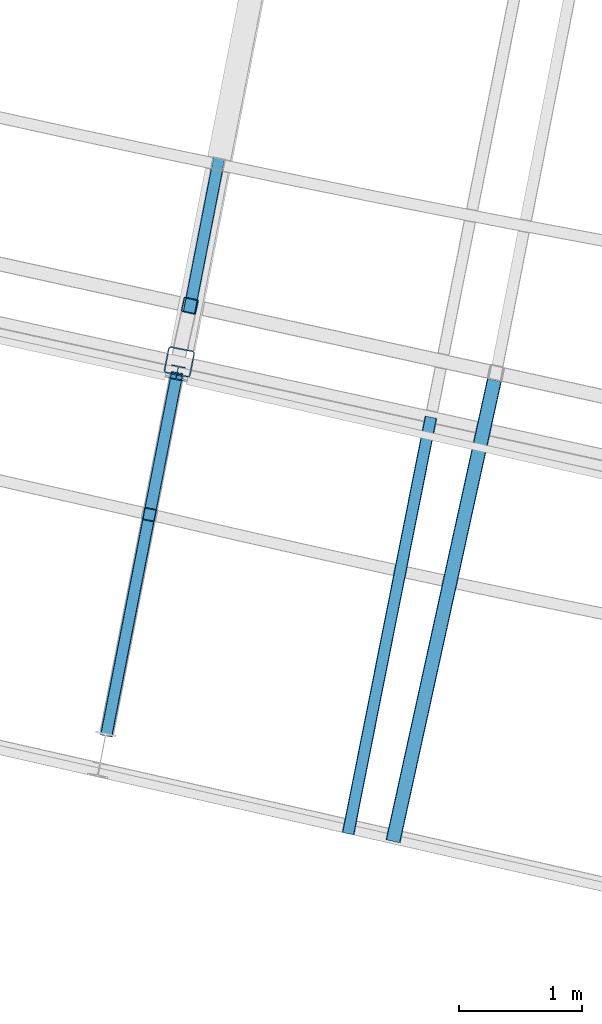
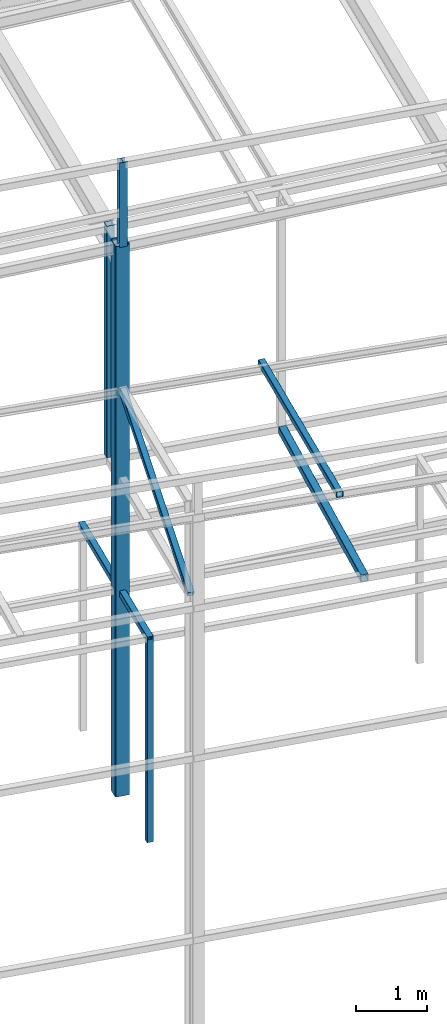
# One storey, part 28 of 215: 8 beams, 1 member, 9 elements without a shape of their own.
"""IFC2X3 building model written with IfcOpenShell, lengths in millimetres."""

from ifc_helpers import new_model, si_unit, frame, origin_with_axes, origin_2d_with_axis, place, context, subcontext, project, spatial, hollow_rectangle, i_section, extrude, clip, halfspace, material, type_object, element, aggregate, save


model = new_model("IFC2X3")

# Units and contexts
model_context = context("Model", 3, precision=1e-05, world=origin_with_axes())
body_context = subcontext(model_context, "Body", "Model", "MODEL_VIEW")
ifc_project = project(units=[si_unit("LENGTHUNIT", "METRE", prefix="MILLI"), si_unit("AREAUNIT", "SQUARE_METRE"), si_unit("VOLUMEUNIT", "CUBIC_METRE"), si_unit("MASSUNIT", "GRAM", prefix="KILO"), si_unit("TIMEUNIT", "SECOND"), si_unit("PLANEANGLEUNIT", "RADIAN"), si_unit("SOLIDANGLEUNIT", "STERADIAN"), si_unit("THERMODYNAMICTEMPERATUREUNIT", "DEGREE_CELSIUS"), si_unit("LUMINOUSINTENSITYUNIT", "LUMEN")], contexts=[model_context])

# Site, building, storey
site_placement = place(None, origin_with_axes())
site = spatial("IfcSite", under=ifc_project, at=site_placement, CompositionType="ELEMENT")
building_placement = place(site_placement, origin_with_axes())
building = spatial("IfcBuilding", under=site, at=building_placement, Name="Undefined", CompositionType="ELEMENT")
storey_placement = place(building_placement, origin_with_axes())
storey = spatial("IfcBuildingStorey", under=building, at=storey_placement, Name="Undefined", CompositionType="ELEMENT", Elevation=0.0)

# Assembly, beam
assembly_1_placement = place(storey_placement, origin_with_axes())
assembly_1 = element("IfcElementAssembly", 1, at=assembly_1_placement, inside=storey, Name="Steel Assembly", AssemblyPlace="NOTDEFINED", PredefinedType="RIGID_FRAME")
ifc_material = material(Name="STEEL/S275JR")
beam_type_1 = type_object("IfcBeamType", PredefinedType="NOTDEFINED")
beam_1_placement = place(assembly_1_placement, frame((59714.7878050659, 5675.63674681573, 6760.00000147429), z_axis=(-0.981422412140383, 0.191859451027444, 0.0), x_axis=(0.0, 0.0, -1.0)))
beam_1 = element("IfcBeam", 2, at=beam_1_placement, type_object=beam_type_1, material=ifc_material, Name="MONTANT", context=body_context, shape_type="SweptSolid", body=[
    extrude(hollow_rectangle(XDim=100.0, YDim=100.0, WallThickness=4.0, InnerFilletRadius=4.0, OuterFilletRadius=8.0, at=origin_2d_with_axis()), frame((3499.99999998675, 0.0, 0.0), z_axis=(-1.0, 0.0, 0.0), x_axis=(-6.93889390390723e-18, -1.0, -3.46944695195361e-18)), (0.0, 0.0, 1.0), 3500.0),
])
aggregate(assembly_1, [beam_1])

assembly_2_placement = place(storey_placement, origin_with_axes())
assembly_2 = element("IfcElementAssembly", 3, at=assembly_2_placement, inside=storey, Name="Steel Assembly", AssemblyPlace="NOTDEFINED", PredefinedType="RIGID_FRAME")
beam_2_placement = place(assembly_2_placement, frame((59705.2313155616, 5626.55621663532, 6760.00000147687), z_axis=(-0.981443928514775, 0.191749355100574, 0.0), x_axis=(0.191749355100576, 0.981443928514774, 0.0)))
beam_2 = element("IfcBeam", 4, at=beam_2_placement, type_object=beam_type_1, material=ifc_material, Name="POUTRE", context=body_context, shape_type="Clipping", body=[
    clip(extrude(hollow_rectangle(XDim=100.0, YDim=100.0, WallThickness=4.0, InnerFilletRadius=4.0, OuterFilletRadius=8.0, at=origin_2d_with_axis()), frame((1205.10261709792, 9.09494701772928e-13, 0.0), z_axis=(-1.0, 0.0, 0.0), x_axis=(-6.93889390390723e-18, -1.0, -3.46944695195361e-18)), (0.0, 0.0, 1.0), 1205.1), halfspace(frame((1205.11495562573, -49.9999999999991, 109.989902511399), z_axis=(-0.999999993707966, 0.0, 0.000112178729892983), x_axis=(-6.93889390390723e-18, -1.0, -3.46944695195361e-18)), True)),
])
aggregate(assembly_2, [beam_2])

assembly_3_placement = place(storey_placement, origin_with_axes())
assembly_3 = element("IfcElementAssembly", 5, at=assembly_3_placement, inside=storey, Name="Steel Assembly", AssemblyPlace="NOTDEFINED", PredefinedType="RIGID_FRAME")
beam_3_placement = place(assembly_3_placement, frame((59995.7953493763, 7113.53585944618, 6760.00000147687), z_axis=(-0.981422412140383, 0.191859451027444, 0.0), x_axis=(0.191859470081235, 0.981422408415534, 0.0)))
beam_3 = element("IfcBeam", 6, at=beam_3_placement, type_object=beam_type_1, material=ifc_material, Name="POUTRE", context=body_context, shape_type="Clipping", body=[
    clip(extrude(hollow_rectangle(XDim=100.0, YDim=100.0, WallThickness=4.0, InnerFilletRadius=4.0, OuterFilletRadius=8.0, at=origin_2d_with_axis()), frame((1486.70401782648, 0.0, 4.12643257848422e-14), z_axis=(-1.0, 0.0, 0.0), x_axis=(-6.93889390390723e-18, -1.0, -3.46944695195361e-18)), (0.0, 0.0, 1.0), 1576.7), halfspace(frame((-89.9999938967303, -50.0, -109.99995330286), z_axis=(1.0, 0.0, 0.0), x_axis=(-6.93889390390723e-18, -1.0, -3.46944695195361e-18)), True)),
])
aggregate(assembly_3, [beam_3])

assembly_4_placement = place(storey_placement, origin_with_axes())
assembly_4 = element("IfcElementAssembly", 7, at=assembly_4_placement, inside=storey, Name="Steel Assembly", AssemblyPlace="NOTDEFINED", PredefinedType="RIGID_FRAME")
beam_type_2 = type_object("IfcBeamType", PredefinedType="NOTDEFINED")
beam_4_placement = place(assembly_4_placement, frame((62518.9973398517, 6768.47178494175, 8706.00017320451), z_axis=(0.976696868550088, -0.214623453901133, -1.0000003380751e-09), x_axis=(-0.214623453901134, -0.976696868550088, 0.0)))
beam_4 = element("IfcBeam", 8, at=beam_4_placement, type_object=beam_type_2, material=ifc_material, Name="LISSE", context=body_context, shape_type="SweptSolid", body=[
    extrude(hollow_rectangle(XDim=120.0, YDim=120.0, WallThickness=5.0, InnerFilletRadius=5.0, OuterFilletRadius=10.0, at=origin_2d_with_axis()), frame((3838.62759718365, 1.81898940364508e-12, 1.06543318533871e-13), z_axis=(-1.0, 0.0, 0.0), x_axis=(-6.93889390390723e-18, -1.0, -3.46944695195361e-18)), (0.0, 0.0, 1.0), 3838.6),
])
aggregate(assembly_4, [beam_4])

assembly_5_placement = place(storey_placement, origin_with_axes())
assembly_5 = element("IfcElementAssembly", 9, at=assembly_5_placement, inside=storey, Name="Steel Assembly", AssemblyPlace="NOTDEFINED", PredefinedType="RIGID_FRAME")
beam_5_placement = place(assembly_5_placement, frame((60043.166993633, 7373.72721898546, 12762.4504231558), z_axis=(-0.214538758981639, -0.97671547591641, 0.0), x_axis=(0.0, 0.0, -1.0)))
beam_5 = element("IfcBeam", 10, at=beam_5_placement, type_object=beam_type_2, material=ifc_material, Name="LISSE", context=body_context, shape_type="SweptSolid", body=[
    extrude(hollow_rectangle(XDim=120.0, YDim=120.0, WallThickness=5.0, InnerFilletRadius=5.0, OuterFilletRadius=10.0, at=origin_2d_with_axis()), frame((3996.44961442818, 0.0, 3.63797880409584e-12), z_axis=(-1.0, 0.0, 0.0), x_axis=(-6.93889390390723e-18, -1.0, -3.46944695195361e-18)), (0.0, 0.0, 1.0), 3996.4),
])
aggregate(assembly_5, [beam_5])

assembly_6_placement = place(storey_placement, origin_with_axes())
assembly_6 = element("IfcElementAssembly", 11, at=assembly_6_placement, inside=storey, Name="Steel Assembly", AssemblyPlace="NOTDEFINED", PredefinedType="RIGID_FRAME")
beam_type_3 = type_object("IfcBeamType", PredefinedType="NOTDEFINED")
beam_6_placement = place(assembly_6_placement, frame((62003.1579182611, 6467.22847660188, 10236.0800002947), z_axis=(0.0, 0.0, -1.0), x_axis=(-0.195014663939707, -0.980800326696766, 0.0)))
beam_6 = element("IfcBeam", 12, at=beam_6_placement, type_object=beam_type_3, material=ifc_material, context=body_context, shape_type="SweptSolid", body=[
    extrude(hollow_rectangle(XDim=100.0, YDim=100.0, WallThickness=5.0, InnerFilletRadius=5.0, OuterFilletRadius=10.0, at=origin_2d_with_axis()), frame((3452.57346573111, 0.0, 0.0), z_axis=(-1.0, 0.0, 0.0), x_axis=(-6.93889390390723e-18, -1.0, -3.46944695195361e-18)), (0.0, 0.0, 1.0), 3452.6),
])
aggregate(assembly_6, [beam_6])

# Assembly, member
assembly_7_placement = place(storey_placement, origin_with_axes())
assembly_7 = element("IfcElementAssembly", 13, at=assembly_7_placement, inside=storey, Name="Steel Assembly", AssemblyPlace="NOTDEFINED", PredefinedType="RIGID_FRAME")
member_type = type_object("IfcMemberType", PredefinedType="NOTDEFINED")
member_placement = place(assembly_7_placement, frame((59936.3192264928, 6809.29485387995, 10271.5286693839), z_axis=(-0.981371881037284, 0.192117106007299, -0.000498687000018282), x_axis=(-0.169779398992978, -0.868475463964083, -0.465752427980739)))
member = element("IfcMember", 14, at=member_placement, type_object=member_type, material=ifc_material, context=body_context, shape_type="SweptSolid", body=[
    extrude(hollow_rectangle(XDim=100.0, YDim=100.0, WallThickness=5.0, InnerFilletRadius=5.0, OuterFilletRadius=10.0, at=origin_2d_with_axis()), frame((3352.7010292879, -7.95807864051312e-13, 1.4285572556818e-13), z_axis=(-1.0, 0.0, 0.0), x_axis=(-6.93889390390723e-18, -1.0, -3.46944695195361e-18)), (0.0, 0.0, 1.0), 3352.7),
])
aggregate(assembly_7, [member])

# Assembly, beam
assembly_8_placement = place(storey_placement, origin_with_axes())
assembly_8 = element("IfcElementAssembly", 15, at=assembly_8_placement, inside=storey, Name="Steel Assembly", AssemblyPlace="NOTDEFINED", PredefinedType="RIGID_FRAME")
beam_type_4 = type_object("IfcBeamType", Name="HEA120", PredefinedType="NOTDEFINED")
beam_7_placement = place(assembly_8_placement, frame((59940.0660631714, 6828.4629894439, 14219.9969934734), z_axis=(0.191859470081235, 0.981422408415534, 0.0), x_axis=(0.0, 0.0, -1.0)))
beam_7 = element("IfcBeam", 16, at=beam_7_placement, type_object=beam_type_4, material=ifc_material, ObjectType="HEA120", context=body_context, shape_type="SweptSolid", body=[
    extrude(i_section(OverallWidth=120.0, OverallDepth=114.0, WebThickness=5.0, FlangeThickness=8.0, FilletRadius=12.0, at=origin_2d_with_axis()), frame((1459.96971340472, -7.27595761410795e-12, 3.01914660460747e-22), z_axis=(-1.0, 0.0, 0.0), x_axis=(-6.93889390390723e-18, -1.0, -3.46944695195361e-18)), (0.0, 0.0, 1.0), 1460.0),
])
aggregate(assembly_8, [beam_7])

assembly_9_placement = place(storey_placement, origin_with_axes())
assembly_9 = element("IfcElementAssembly", 17, at=assembly_9_placement, inside=storey, Name="Steel Assembly", AssemblyPlace="NOTDEFINED", PredefinedType="RIGID_FRAME")
beam_type_5 = type_object("IfcBeamType", PredefinedType="NOTDEFINED")
beam_8_placement = place(assembly_9_placement, frame((59957.4234138413, 6917.25139159045, 12760.0272799372), z_axis=(0.191859470081235, 0.981422408415534, 0.0), x_axis=(0.0, 0.0, -1.0)))
beam_8 = element("IfcBeam", 18, at=beam_8_placement, type_object=beam_type_5, material=ifc_material, Name="POTEAU", context=body_context, shape_type="SweptSolid", body=[
    extrude(hollow_rectangle(XDim=220.0, YDim=220.0, WallThickness=10.0, InnerFilletRadius=15.0, OuterFilletRadius=25.0, at=origin_2d_with_axis()), frame((9500.02936992614, 0.0, 0.0), z_axis=(-1.0, 0.0, 0.0), x_axis=(-6.93889390390723e-18, -1.0, -3.46944695195361e-18)), (0.0, 0.0, 1.0), 9500.0),
])
aggregate(assembly_9, [beam_8])

save(model, "model.ifc")
